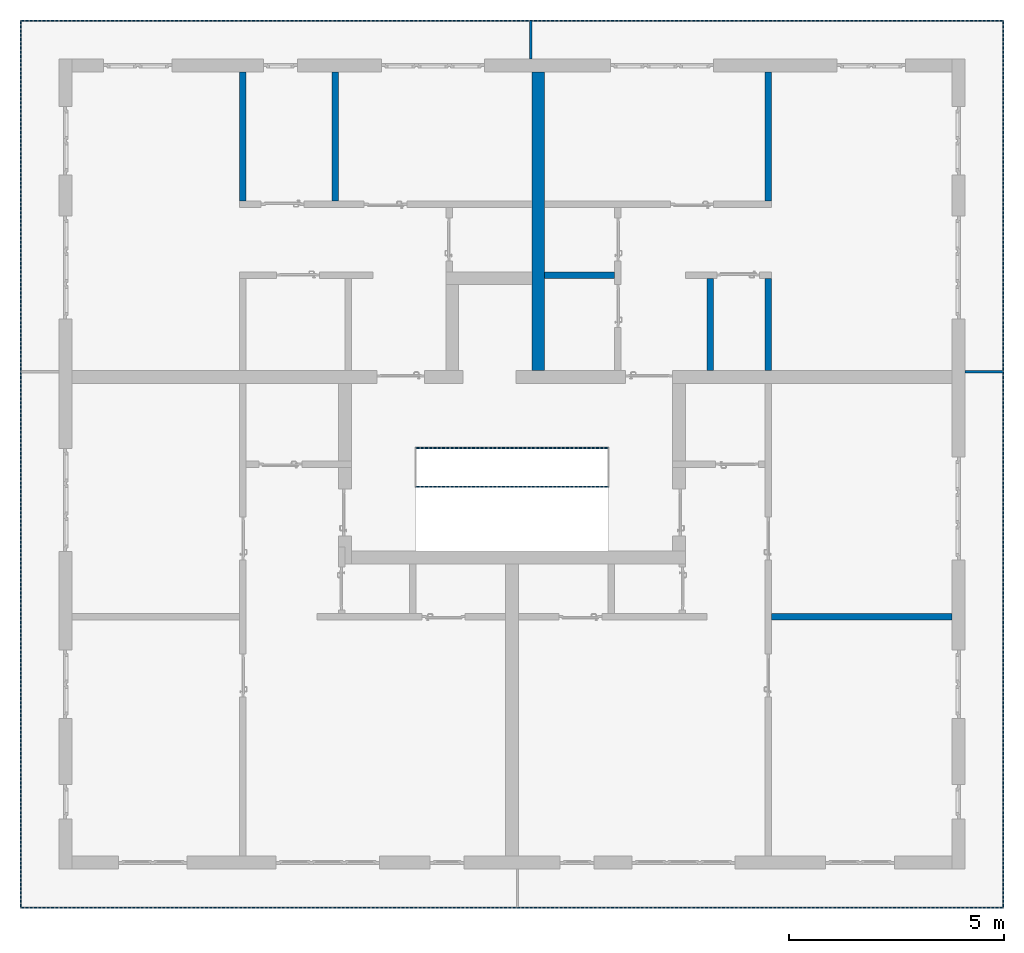
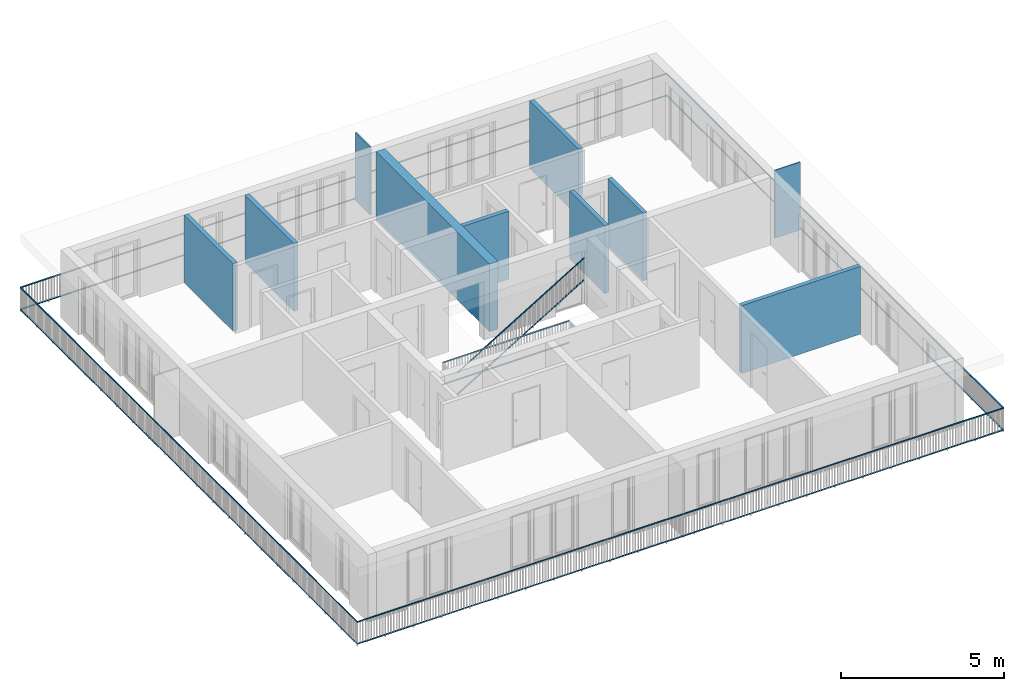
# One storey, part 30 of 54: 12 building element parts, 10 walls, 3 elements without a shape of their own.
"""IFC4 building model written with IfcOpenShell, lengths in metres."""

import ifcopenshell
import ifcopenshell.guid

model = None  # the IFC model being written
_history = None  # IfcOwnerHistory: only IFC2X3 demands one
_inside = {}  # id of a spatial element -> (the spatial element, [elements in it])
_under = {}  # id of a project, library or spatial element -> (it, [spatial elements below it])
_declared = {}  # id of a project -> (the project, [libraries it declares])
_typed = {}  # id of a type object -> (the type object, [elements of that type])
_made_of = {}  # id of a material, layer set ... -> (it, [elements and type objects made of it])


def new_model(schema):
    """Start an empty IFC model of exactly this schema.

    Asked for "IFC4X3", IfcOpenShell would pick the latest addendum, in which some entities
    have other attributes; the version numbers below select the first issue.
    IFC2X3 requires an IfcOwnerHistory on every rooted entity: one is made here for all.
    """
    global model, _history
    if schema == "IFC4X3":
        model = ifcopenshell.file(schema_version=(4, 3, 0, 0))
    else:
        model = ifcopenshell.file(schema=schema)
    _inside.clear()
    _under.clear()
    _declared.clear()
    _typed.clear()
    _made_of.clear()
    _history = None
    if model.schema == "IFC2X3":
        org = make("IfcOrganization", Name="unknown")
        user = make(
            "IfcPersonAndOrganization",
            ThePerson=make("IfcPerson", FamilyName="unknown"),
            TheOrganization=org,
        )
        app = make(
            "IfcApplication",
            ApplicationDeveloper=org,
            Version="unknown",
            ApplicationFullName="unknown",
            ApplicationIdentifier="unknown",
        )
        _history = make(
            "IfcOwnerHistory",
            OwningUser=user,
            OwningApplication=app,
            ChangeAction="ADDED",
            CreationDate=0,
        )
    return model


def make(cls, **values):
    """One entity of the class cls with the attributes given. An attribute that is None is left unset."""
    return model.create_entity(
        cls, **{name: value for name, value in values.items() if value is not None}
    )


def entity(cls, *values):
    """Any entity or typed value of the class cls, its attributes in the order of the schema. None: left unset."""
    e = model.create_entity(cls)
    for i, value in enumerate(values):
        if value is not None:
            e[i] = value
    return e


def rooted(cls, **values):
    """An entity with a GlobalId (a new one), such as an element, a storey or a relation."""
    return make(cls, GlobalId=ifcopenshell.guid.new(), OwnerHistory=_history, **values)


def si_unit(unit_type, name, prefix=None):
    """IfcSIUnit, for example si_unit("LENGTHUNIT", "METRE", prefix="MILLI")."""
    return make("IfcSIUnit", UnitType=unit_type, Prefix=prefix, Name=name)


def converted_unit(unit_type, name, factor, base, dimensions=None, offset=None):
    """IfcConversionBasedUnit, such as the inch: factor (a typed value) times the base unit."""
    return make(
        "IfcConversionBasedUnit"
        if offset is None
        else "IfcConversionBasedUnitWithOffset",
        ConversionOffset=offset,
        Dimensions=None
        if dimensions is None
        else entity("IfcDimensionalExponents", *dimensions),
        UnitType=unit_type,
        Name=name,
        ConversionFactor=make(
            "IfcMeasureWithUnit", ValueComponent=factor, UnitComponent=base
        ),
    )


def derived_unit(unit_type, elements):
    """IfcDerivedUnit: a product of units, each with its exponent."""
    return make(
        "IfcDerivedUnit",
        Elements=[
            make("IfcDerivedUnitElement", Unit=unit, Exponent=power)
            for unit, power in elements
        ],
        UnitType=unit_type,
    )


def assignment(units):
    """IfcUnitAssignment: the units of a project."""
    return None if units is None else make("IfcUnitAssignment", Units=units)


def point(xyz):
    """IfcCartesianPoint."""
    return None if xyz is None else make("IfcCartesianPoint", Coordinates=xyz)


def direction(xyz):
    """IfcDirection."""
    return None if xyz is None else make("IfcDirection", DirectionRatios=xyz)


def frame(location, z_axis=None, x_axis=None):
    """IfcAxis2Placement3D, a coordinate frame: its origin and axes. An axis left out is left unset."""
    return make(
        "IfcAxis2Placement3D",
        Location=point(location),
        Axis=direction(z_axis),
        RefDirection=direction(x_axis),
    )


def origin_with_axes():
    """The frame at (0, 0, 0) with the z axis (0, 0, 1) and the x axis (1, 0, 0) written out."""
    return frame((0.0, 0.0, 0.0), z_axis=(0.0, 0.0, 1.0), x_axis=(1.0, 0.0, 0.0))


def place(relative_to, where):
    """IfcLocalPlacement: puts the frame where relative to a parent placement (None: the world)."""
    return make(
        "IfcLocalPlacement", PlacementRelTo=relative_to, RelativePlacement=where
    )


def context(
    kind, dimensions, precision=None, world=None, true_north=None, identifier=None
):
    """IfcGeometricRepresentationContext, for example the 3D "Model" context."""
    return make(
        "IfcGeometricRepresentationContext",
        ContextIdentifier=identifier,
        ContextType=kind,
        CoordinateSpaceDimension=dimensions,
        Precision=precision,
        WorldCoordinateSystem=world,
        TrueNorth=true_north,
    )


def subcontext(parent, identifier, kind, view, scale=None):
    """IfcGeometricRepresentationSubContext, for example "Body" below "Model"."""
    return make(
        "IfcGeometricRepresentationSubContext",
        ContextIdentifier=identifier,
        ContextType=kind,
        ParentContext=parent,
        TargetScale=scale,
        TargetView=view,
    )


def project(units=None, contexts=None):
    """IfcProject with its units and contexts."""
    return rooted(
        "IfcProject",
        Name="project",
        RepresentationContexts=contexts,
        UnitsInContext=assignment(units),
    )


def spatial(cls, under=None, at=None, **own):
    """A site, building, storey or space (cls), placed at a placement, below another one or the project."""
    s = rooted(cls, ObjectPlacement=at, **own)
    if under is not None:
        _under.setdefault(under.id(), (under, []))[1].append(s)
    return s


def point_list(points):
    """IfcCartesianPointList2D or 3D."""
    cls = (
        "IfcCartesianPointList2D" if len(points[0]) == 2 else "IfcCartesianPointList3D"
    )
    return make(cls, CoordList=points)


def polygons(points, faces, closed=None, point_numbers=None):
    """IfcPolygonalFaceSet: a face is its outer loop, then its inner loops; points numbered from 1."""
    made = []
    for loops in faces:
        if len(loops) == 1:
            made.append(make("IfcIndexedPolygonalFace", CoordIndex=loops[0]))
        else:
            made.append(
                make(
                    "IfcIndexedPolygonalFaceWithVoids",
                    CoordIndex=loops[0],
                    InnerCoordIndices=loops[1:],
                )
            )
    return make(
        "IfcPolygonalFaceSet",
        Coordinates=point_list(points),
        Closed=closed,
        Faces=made,
        PnIndex=point_numbers,
    )


def shape(context_of_items, identifier, shape_type, items):
    """IfcShapeRepresentation: the items that make up one representation, for example the "Body"."""
    return make(
        "IfcShapeRepresentation",
        ContextOfItems=context_of_items,
        RepresentationIdentifier=identifier,
        RepresentationType=shape_type,
        Items=items,
    )


def material(Name=None, Category=None):
    """IfcMaterial."""
    return make("IfcMaterial", Name=Name, Category=Category)


def made_of(thing, what):
    """Note that an element or type object is made of a material, layer set ...; save() writes the relation."""
    if what is not None:
        _made_of.setdefault(what.id(), (what, []))[1].append(thing)
    return thing


def type_object(cls, material=None, **own):
    """A type object (cls), such as IfcWallType, which elements share."""
    return made_of(rooted(cls, **own), material)


def element(
    cls,
    number,
    at=None,
    inside=None,
    cuts=None,
    type_object=None,
    material=None,
    context=None,
    identifier="Body",
    shape_type=None,
    held_by="IfcProductDefinitionShape",
    body=None,
    shapes=None,
    **own,
):
    """One element of the class cls, such as IfcWall. Its Tag is "e" and its number.

    at: its placement. inside: the storey or other place that contains it. cuts: it is an
    opening in that element (IfcRelVoidsElement). A single representation is given by context,
    identifier, shape_type and body (its items); several are given by shapes. held_by: the class
    of the entity that holds the representations. save() writes the other relations.
    """
    e = rooted(cls, Tag="e%d" % number, ObjectPlacement=at, **own)
    if body is not None:
        shapes = [shape(context, identifier, shape_type, body)]
    if shapes is not None:
        e.Representation = make(held_by, Representations=shapes)
    if inside is not None:
        _inside.setdefault(inside.id(), (inside, []))[1].append(e)
    if cuts is not None:
        rooted(
            "IfcRelVoidsElement", RelatingBuildingElement=cuts, RelatedOpeningElement=e
        )
    if type_object is not None:
        _typed.setdefault(type_object.id(), (type_object, []))[1].append(e)
    return made_of(e, material)


def aggregate(whole, parts):
    """IfcRelAggregates: a whole, such as a stair, and the parts it consists of."""
    return rooted("IfcRelAggregates", RelatingObject=whole, RelatedObjects=parts)


def save(model, path):
    """Write the relations noted so far, then the file.

    IfcRelAggregates (storeys below a building ...), IfcRelContainedInSpatialStructure (elements
    in a storey), IfcRelDefinesByType, IfcRelAssociatesMaterial and IfcRelDeclares: one each for
    every whole, place, type object, material and project.
    """
    for whole, parts in _under.values():
        aggregate(whole, parts)
    for where, things in _inside.values():
        rooted(
            "IfcRelContainedInSpatialStructure",
            RelatedElements=things,
            RelatingStructure=where,
        )
    for kind, things in _typed.values():
        rooted("IfcRelDefinesByType", RelatedObjects=things, RelatingType=kind)
    for what, things in _made_of.values():
        rooted("IfcRelAssociatesMaterial", RelatedObjects=things, RelatingMaterial=what)
    for by, libraries in _declared.values():
        rooted("IfcRelDeclares", RelatingContext=by, RelatedDefinitions=libraries)
    model.write(path)


model = new_model("IFC4")

# Units and contexts
model_context = context("Model", 3, precision=1e-05, world=origin_with_axes(), true_north=direction((0.0, 1.0)))
body_context = subcontext(model_context, "Body", "Model", "MODEL_VIEW")
ifc_project = project(units=[si_unit("LENGTHUNIT", "METRE"), si_unit("AREAUNIT", "SQUARE_METRE"), si_unit("VOLUMEUNIT", "CUBIC_METRE"), converted_unit("PLANEANGLEUNIT", "DEGREE", entity("IfcPlaneAngleMeasure", 0.0174532925199), si_unit("PLANEANGLEUNIT", "RADIAN"), dimensions=[0, 0, 0, 0, 0, 0, 0]), converted_unit("TIMEUNIT", "Year", entity("IfcTimeMeasure", 31556926.0), si_unit("TIMEUNIT", "SECOND"), dimensions=[0, 0, 1, 0, 0, 0, 0]), si_unit("MASSUNIT", "GRAM", prefix="KILO"), si_unit("THERMODYNAMICTEMPERATUREUNIT", "DEGREE_CELSIUS"), si_unit("LUMINOUSINTENSITYUNIT", "LUMEN"), si_unit("ENERGYUNIT", "JOULE", prefix="MEGA"), derived_unit("THERMALCONDUCTANCEUNIT", [(si_unit("POWERUNIT", "WATT"), 1), (si_unit("LENGTHUNIT", "METRE"), -1), (si_unit("THERMODYNAMICTEMPERATUREUNIT", "KELVIN"), -1)]), derived_unit("SPECIFICHEATCAPACITYUNIT", [(si_unit("ENERGYUNIT", "JOULE"), 1), (si_unit("MASSUNIT", "GRAM", prefix="KILO"), -1), (si_unit("THERMODYNAMICTEMPERATUREUNIT", "KELVIN"), -1)]), derived_unit("MASSDENSITYUNIT", [(si_unit("MASSUNIT", "GRAM", prefix="KILO"), 1), (si_unit("VOLUMEUNIT", "CUBIC_METRE"), -1)])], contexts=[model_context])

# Site, building, storey
site_placement = place(None, origin_with_axes())
site = spatial("IfcSite", under=ifc_project, at=site_placement, CompositionType="ELEMENT")
building_placement = place(site_placement, origin_with_axes())
building = spatial("IfcBuilding", under=site, at=building_placement, CompositionType="ELEMENT")
storey_placement = place(building_placement, frame((0.0, 0.0, 6.29), z_axis=(0.0, 0.0, 1.0), x_axis=(1.0, 0.0, 0.0)))
storey = spatial("IfcBuildingStorey", under=building, at=storey_placement, Name="2. Geschoss", CompositionType="ELEMENT", Elevation=6.29)

# Walls
ifc_material_1 = material()
wall_type_1 = type_object("IfcWallType", Name="300", PredefinedType="NOTDEFINED")
wall_1_placement = place(storey_placement, frame((-0.742199380397, 1.37118776896, 0.0), z_axis=(0.0, 0.0, 1.0), x_axis=(0.0, 1.0, 0.0)))
element("IfcWall", 1, at=wall_1_placement, inside=storey, type_object=wall_type_1, material=ifc_material_1, Name="Wand-001", PredefinedType="NOTDEFINED", context=body_context, shape_type="Tessellation", body=[
    polygons([(7.25, 0.0, 0.0), (7.25, 0.0, 2.54), (7.25, -0.3, 2.54), (7.25, -0.3, 0.0), (0.3, 0.0, 0.0), (0.3, 0.0, 2.54), (0.3, -0.3, 2.54), (0.3, -0.3, 0.0)], [[[1, 2, 3, 4]], [[5, 6, 2, 1]], [[6, 7, 3, 2]], [[4, 3, 7, 8]], [[8, 5, 1, 4]], [[8, 7, 6, 5]]], closed=True),
])
wall_type_2 = type_object("IfcWallType", Name="150", PredefinedType="NOTDEFINED")
wall_2_placement = place(storey_placement, frame((-7.5421993804, 5.47118776896, 0.0), z_axis=(0.0, 0.0, 1.0), x_axis=(0.0, 1.0, 0.0)))
element("IfcWall", 2, at=wall_2_placement, inside=storey, type_object=wall_type_2, material=ifc_material_1, Name="Wand-002", PredefinedType="NOTDEFINED", context=body_context, shape_type="Tessellation", body=[
    polygons([(3.15, 0.0, 0.0), (3.15, 0.0, 2.54), (3.15, -0.15, 2.54), (3.15, -0.15, 0.0), (0.15, 0.0, 0.0), (0.15, 0.0, 2.54), (0.15, -0.15, 2.54), (0.15, -0.15, 0.0)], [[[1, 2, 3, 4]], [[5, 6, 2, 1]], [[6, 7, 3, 2]], [[4, 3, 7, 8]], [[5, 1, 4, 8]], [[8, 7, 6, 5]]], closed=True),
])
wall_3_placement = place(storey_placement, frame((3.3378006196, 1.37118776896, 0.0), z_axis=(0.0, 0.0, 1.0), x_axis=(0.0, 1.0, 0.0)))
element("IfcWall", 3, at=wall_3_placement, inside=storey, type_object=wall_type_2, material=ifc_material_1, Name="Wand-002", PredefinedType="NOTDEFINED", context=body_context, shape_type="Tessellation", body=[
    polygons([(2.45, 0.0, 0.0), (2.45, 0.0, 2.54), (2.45, -0.15, 2.54), (2.45, -0.15, 0.0), (0.3, 0.0, 0.0), (0.3, 0.0, 2.54), (0.3, -0.15, 2.54), (0.3, -0.15, 0.0)], [[[1, 2, 3, 4]], [[5, 6, 2, 1]], [[6, 7, 3, 2]], [[4, 3, 7, 8]], [[5, 1, 4, 8]], [[8, 7, 6, 5]]], closed=True),
])
wall_4_placement = place(storey_placement, frame((1.3378006196, 3.97118776896, 0.0), z_axis=(0.0, 0.0, 1.0), x_axis=(-1.0, 0.0, 0.0)))
element("IfcWall", 4, at=wall_4_placement, inside=storey, type_object=wall_type_2, material=ifc_material_1, Name="Wand-002", PredefinedType="NOTDEFINED", context=body_context, shape_type="Tessellation", body=[
    polygons([(1.78, 0.0, 0.0), (1.78, 0.0, 2.54), (0.15, 0.0, 2.54), (0.15, 0.0, 0.0), (1.78, 0.15, 0.0), (1.78, 0.15, 2.54), (0.15, 0.15, 2.54), (0.15, 0.15, 0.0)], [[[1, 2, 3, 4]], [[5, 6, 2, 1]], [[6, 7, 3, 2]], [[4, 3, 7, 8]], [[8, 5, 1, 4]], [[8, 7, 6, 5]]], closed=True),
])
for number, where, z_axis, x_axis, name in (
    (5, (-5.3921993804, 5.47118776896, 0.0), (0.0, 0.0, 1.0), (0.0, 1.0, 0.0), "Wand-002"),
    (6, (4.6878006196, 5.47118776896, 0.0), (0.0, 0.0, 1.0), (0.0, 1.0, 0.0), "Wand-002"),
):
    element("IfcWall", number, at=place(storey_placement, frame(where, z_axis=z_axis, x_axis=x_axis)), inside=storey, type_object=wall_type_2, material=ifc_material_1, Name=name, PredefinedType="NOTDEFINED", context=body_context, shape_type="Tessellation", body=[
        polygons([(3.15, 0.0, 0.0), (3.15, 0.0, 2.54), (3.15, -0.15, 2.54), (3.15, -0.15, 0.0), (0.15, 0.0, 0.0), (0.15, 0.0, 2.54), (0.15, -0.15, 2.54), (0.15, -0.15, 0.0)], [[[1, 2, 3, 4]], [[5, 6, 2, 1]], [[6, 7, 3, 2]], [[4, 3, 7, 8]], [[5, 1, 4, 8]], [[8, 7, 6, 5]]], closed=True),
    ])
wall_5_placement = place(storey_placement, frame((9.3378006196, -4.12881223104, 0.0), z_axis=(0.0, 0.0, 1.0), x_axis=(-1.0, 0.0, 0.0)))
element("IfcWall", 7, at=wall_5_placement, inside=storey, type_object=wall_type_2, material=ifc_material_1, Name="Wand-004", PredefinedType="NOTDEFINED", context=body_context, shape_type="Tessellation", body=[
    polygons([(4.5, -0.15, 0.0), (4.5, -0.15, 2.54), (0.3, -0.15, 2.54), (0.3, -0.15, 0.0), (4.5, 0.0, 0.0), (4.5, 0.0, 2.54), (0.3, 0.0, 2.54), (0.3, 0.0, 0.0)], [[[1, 2, 3, 4]], [[5, 6, 2, 1]], [[6, 7, 3, 2]], [[4, 3, 7, 8]], [[8, 5, 1, 4]], [[8, 7, 6, 5]]], closed=True),
])
wall_6_placement = place(storey_placement, frame((4.6878006196, 1.37118776896, 0.0), z_axis=(0.0, 0.0, 1.0), x_axis=(0.0, 1.0, 0.0)))
element("IfcWall", 8, at=wall_6_placement, inside=storey, type_object=wall_type_2, material=ifc_material_1, Name="Wand-002", PredefinedType="NOTDEFINED", context=body_context, shape_type="Tessellation", body=[
    polygons([(2.45, 0.0, 0.0), (2.45, 0.0, 2.54), (2.45, -0.15, 2.54), (2.45, -0.15, 0.0), (0.3, 0.0, 0.0), (0.3, 0.0, 2.54), (0.3, -0.15, 2.54), (0.3, -0.15, 0.0)], [[[1, 2, 3, 4]], [[5, 6, 2, 1]], [[6, 7, 3, 2]], [[4, 3, 7, 8]], [[5, 1, 4, 8]], [[8, 7, 6, 5]]], closed=True),
])
ifc_material_2 = material()
wall_type_3 = type_object("IfcWallType", Name="50", PredefinedType="NOTDEFINED")
wall_7_placement = place(storey_placement, frame((-0.742199380397, 9.82118776896, 0.0), z_axis=(0.0, 0.0, 1.0), x_axis=(0.0, -1.0, 0.0)))
element("IfcWall", 9, at=wall_7_placement, inside=storey, type_object=wall_type_3, material=ifc_material_2, Name="Wand-003", PredefinedType="NOTDEFINED", context=body_context, shape_type="Tessellation", body=[
    polygons([(0.0, -0.05, 2.54), (0.0, 0.0, 2.54), (0.0, 0.0, 0.0), (0.0, -0.05, 0.0), (0.9, 0.0, 2.54), (0.9, -0.05, 2.54), (0.9, 0.0, 0.0), (0.9, -0.05, 0.0)], [[[1, 2, 3, 4]], [[5, 2, 1, 6]], [[2, 5, 7, 3]], [[7, 8, 4, 3]], [[6, 1, 4, 8]], [[5, 6, 8, 7]]], closed=True),
])
wall_8_placement = place(storey_placement, frame((9.0378006196, 1.67118776896, 0.0), z_axis=(0.0, 0.0, 1.0), x_axis=(1.0, 0.0, 0.0)))
element("IfcWall", 10, at=wall_8_placement, inside=storey, type_object=wall_type_3, material=ifc_material_2, Name="Wand-003", PredefinedType="NOTDEFINED", context=body_context, shape_type="Tessellation", body=[
    polygons([(0.3, 0.0, 2.54), (1.2, 0.0, 2.54), (1.2, 0.0, 0.0), (0.3, 0.0, 0.0), (1.2, -0.05, 2.54), (0.3, -0.05, 2.54), (1.2, -0.05, 0.0), (0.3, -0.05, 0.0)], [[[1, 2, 3, 4]], [[5, 2, 1, 6]], [[2, 5, 7, 3]], [[4, 3, 7, 8]], [[6, 1, 4, 8]], [[5, 6, 8, 7]]], closed=True),
])

# Space
space_1_placement = place(storey_placement, frame((-3.4421993804, -2.52881223104, 0.0), z_axis=(0.0, 0.0, 1.0), x_axis=(1.0, 0.0, 0.0)))
space_1 = spatial("IfcSpace", under=storey, at=space_1_placement, CompositionType="ELEMENT", PredefinedType="INTERNAL")

# Railing, building element parts
railing_type = type_object("IfcRailingType", PredefinedType="NOTDEFINED")
railing_1_placement = place(space_1_placement, frame((0.0, 1.5, 0.0), z_axis=(0.0, 0.0, 1.0), x_axis=(1.0, 0.0, 0.0)))
railing_1 = element("IfcRailing", 11, at=railing_1_placement, inside=space_1, type_object=railing_type, PredefinedType="NOTDEFINED")
ifc_material_3 = material()
building_element_part_1_placement = place(railing_1_placement, origin_with_axes())
building_element_part_1 = element("IfcBuildingElementPart", 12, at=building_element_part_1_placement, material=ifc_material_3, PredefinedType="NOTDEFINED", context=body_context, shape_type="Tessellation", body=[
    polygons([(0.0125, 0.8875, 0.9), (0.0125, 0.8875, 0.875), (4.4675, 0.8875, 0.875), (4.4675, 0.8875, 0.9), (-0.0125, 0.9125, 0.9), (-0.0125, 0.9125, 0.875), (4.4925, 0.9125, 0.875), (4.4925, 0.9125, 0.9)], [[[1, 2, 3, 4]], [[1, 5, 6, 2]], [[2, 6, 7, 3]], [[4, 3, 7, 8]], [[5, 1, 4, 8]], [[6, 5, 8, 7]]], closed=True),
])
building_element_part_2_placement = place(railing_1_placement, origin_with_axes())
building_element_part_2 = element("IfcBuildingElementPart", 13, at=building_element_part_2_placement, material=ifc_material_3, PredefinedType="NOTDEFINED", context=body_context, shape_type="Tessellation", body=[
    polygons([(0.0125, 0.8875, 0.0825), (0.0125, 0.8875, 0.0575), (4.4675, 0.8875, 0.0575), (4.4675, 0.8875, 0.0825), (-0.0125, 0.9125, 0.0825), (-0.0125, 0.9125, 0.0575), (4.4925, 0.9125, 0.0575), (4.4925, 0.9125, 0.0825)], [[[1, 2, 3, 4]], [[1, 5, 6, 2]], [[2, 6, 7, 3]], [[4, 3, 7, 8]], [[5, 1, 4, 8]], [[6, 5, 8, 7]]], closed=True),
])
aggregate(railing_1, [building_element_part_1, building_element_part_2])

railing_2_placement = place(space_1_placement, frame((0.0, 1.5, 0.17), z_axis=(0.0, 0.0, 1.0), x_axis=(1.0, 0.0, 0.0)))
railing_2 = element("IfcRailing", 14, at=railing_2_placement, inside=space_1, type_object=railing_type, PredefinedType="NOTDEFINED")
building_element_part_3_placement = place(railing_2_placement, origin_with_axes())
building_element_part_3 = element("IfcBuildingElementPart", 15, at=building_element_part_3_placement, material=ifc_material_3, PredefinedType="NOTDEFINED", context=body_context, shape_type="Tessellation", body=[
    polygons([(0.0, -0.0125, 0.9), (0.012974453356, -0.0125, 0.878630312119), (4.49297445336, -0.0125, 3.59863031212), (4.48, -0.0125, 3.62), (0.0, 0.0125, 0.9), (0.012974453356, 0.0125, 0.878630312119), (4.49297445336, 0.0125, 3.59863031212), (4.48, 0.0125, 3.62)], [[[1, 2, 3, 4]], [[1, 5, 6, 2]], [[2, 6, 7, 3]], [[4, 3, 7, 8]], [[5, 1, 4, 8]], [[6, 5, 8, 7]]], closed=True),
])
building_element_part_4_placement = place(railing_2_placement, origin_with_axes())
building_element_part_4 = element("IfcBuildingElementPart", 16, at=building_element_part_4_placement, material=ifc_material_3, PredefinedType="NOTDEFINED", context=body_context, shape_type="Tessellation", body=[
    polygons([(-0.00648722667802, -0.0125, 0.0806848439403), (0.00648722667802, -0.0125, 0.0593151560597), (4.48648722668, -0.0125, 2.77931515606), (4.47351277332, -0.0125, 2.80068484394), (-0.00648722667802, 0.0125, 0.0806848439403), (0.00648722667802, 0.0125, 0.0593151560597), (4.48648722668, 0.0125, 2.77931515606), (4.47351277332, 0.0125, 2.80068484394)], [[[1, 2, 3, 4]], [[1, 5, 6, 2]], [[2, 6, 7, 3]], [[4, 3, 7, 8]], [[5, 1, 4, 8]], [[6, 5, 8, 7]]], closed=True),
])
aggregate(railing_2, [building_element_part_3, building_element_part_4])

# Space
space_2_placement = place(storey_placement, frame((10.2378006196, 9.82118769833, 0.0), z_axis=(0.0, 0.0, 1.0), x_axis=(-1.0, 0.0, 0.0)))
space_2 = spatial("IfcSpace", under=storey, at=space_2_placement, CompositionType="ELEMENT", PredefinedType="EXTERNAL")

# Railing, building element parts
railing_3_placement = place(space_2_placement, frame((0.0, -7.06315681498e-08, 0.0), z_axis=(0.0, 0.0, 1.0), x_axis=(-1.0, 0.0, 0.0)))
railing_3 = element("IfcRailing", 17, at=railing_3_placement, inside=space_2, type_object=railing_type, PredefinedType="NOTDEFINED")
building_element_part_5_placement = place(railing_3_placement, origin_with_axes())
building_element_part_5 = element("IfcBuildingElementPart", 18, at=building_element_part_5_placement, material=ifc_material_3, PredefinedType="NOTDEFINED", context=body_context, shape_type="Tessellation", body=[
    polygons([(0.0, 0.0125, 0.9), (0.0, 0.0125, 0.875), (-22.8925, 0.0125, 0.875), (-22.8925, 0.0125, 0.9), (0.0, -0.0125, 0.9), (0.0, -0.0125, 0.875), (-22.8675, -0.0125, 0.875), (-22.8675, -0.0125, 0.9)], [[[1, 2, 3, 4]], [[1, 5, 6, 2]], [[2, 6, 7, 3]], [[4, 3, 7, 8]], [[5, 1, 4, 8]], [[6, 5, 8, 7]]], closed=True),
])
building_element_part_6_placement = place(railing_3_placement, origin_with_axes())
building_element_part_6 = element("IfcBuildingElementPart", 19, at=building_element_part_6_placement, material=ifc_material_3, PredefinedType="NOTDEFINED", context=body_context, shape_type="Tessellation", body=[
    polygons([(0.0, 0.0125, 0.0825), (0.0, 0.0125, 0.0575), (-22.8925, 0.0125, 0.0575), (-22.8925, 0.0125, 0.0825), (0.0, -0.0125, 0.0825), (0.0, -0.0125, 0.0575), (-22.8675, -0.0125, 0.0575), (-22.8675, -0.0125, 0.0825)], [[[1, 2, 3, 4]], [[1, 5, 6, 2]], [[2, 6, 7, 3]], [[4, 3, 7, 8]], [[5, 1, 4, 8]], [[6, 5, 8, 7]]], closed=True),
])
building_element_part_7_placement = place(railing_3_placement, origin_with_axes())
building_element_part_7 = element("IfcBuildingElementPart", 20, at=building_element_part_7_placement, material=ifc_material_3, PredefinedType="NOTDEFINED", context=body_context, shape_type="Tessellation", body=[
    polygons([(-22.8925, 0.0125, 0.9), (-22.8925, 0.0125, 0.875), (-22.8925, -20.6625, 0.875), (-22.8925, -20.6625, 0.9), (-22.8675, -0.0125, 0.9), (-22.8675, -0.0125, 0.875), (-22.8675, -20.6375, 0.875), (-22.8675, -20.6375, 0.9)], [[[1, 2, 3, 4]], [[1, 5, 6, 2]], [[2, 6, 7, 3]], [[4, 3, 7, 8]], [[5, 1, 4, 8]], [[6, 5, 8, 7]]], closed=True),
])
building_element_part_8_placement = place(railing_3_placement, origin_with_axes())
building_element_part_8 = element("IfcBuildingElementPart", 21, at=building_element_part_8_placement, material=ifc_material_3, PredefinedType="NOTDEFINED", context=body_context, shape_type="Tessellation", body=[
    polygons([(-22.8925, 0.0125, 0.0825), (-22.8925, 0.0125, 0.0575), (-22.8925, -20.6625, 0.0575), (-22.8925, -20.6625, 0.0825), (-22.8675, -0.0125, 0.0825), (-22.8675, -0.0125, 0.0575), (-22.8675, -20.6375, 0.0575), (-22.8675, -20.6375, 0.0825)], [[[1, 2, 3, 4]], [[1, 5, 6, 2]], [[2, 6, 7, 3]], [[4, 3, 7, 8]], [[5, 1, 4, 8]], [[6, 5, 8, 7]]], closed=True),
])
building_element_part_9_placement = place(railing_3_placement, origin_with_axes())
building_element_part_9 = element("IfcBuildingElementPart", 22, at=building_element_part_9_placement, material=ifc_material_3, PredefinedType="NOTDEFINED", context=body_context, shape_type="Tessellation", body=[
    polygons([(-22.8925, -20.6625, 0.9), (-22.8925, -20.6625, 0.875), (0.0125, -20.6625, 0.875), (0.0125, -20.6625, 0.9), (-22.8675, -20.6375, 0.9), (-22.8675, -20.6375, 0.875), (-0.0125, -20.6375, 0.875), (-0.0125, -20.6375, 0.9)], [[[1, 2, 3, 4]], [[1, 5, 6, 2]], [[2, 6, 7, 3]], [[4, 3, 7, 8]], [[5, 1, 4, 8]], [[6, 5, 8, 7]]], closed=True),
])
building_element_part_10_placement = place(railing_3_placement, origin_with_axes())
building_element_part_10 = element("IfcBuildingElementPart", 23, at=building_element_part_10_placement, material=ifc_material_3, PredefinedType="NOTDEFINED", context=body_context, shape_type="Tessellation", body=[
    polygons([(-22.8925, -20.6625, 0.0825), (-22.8925, -20.6625, 0.0575), (0.0125, -20.6625, 0.0575), (0.0125, -20.6625, 0.0825), (-22.8675, -20.6375, 0.0825), (-22.8675, -20.6375, 0.0575), (-0.0125, -20.6375, 0.0575), (-0.0125, -20.6375, 0.0825)], [[[1, 2, 3, 4]], [[1, 5, 6, 2]], [[2, 6, 7, 3]], [[4, 3, 7, 8]], [[5, 1, 4, 8]], [[6, 5, 8, 7]]], closed=True),
])
building_element_part_11_placement = place(railing_3_placement, origin_with_axes())
building_element_part_11 = element("IfcBuildingElementPart", 24, at=building_element_part_11_placement, material=ifc_material_3, PredefinedType="NOTDEFINED", context=body_context, shape_type="Tessellation", body=[
    polygons([(0.0125, -20.6625, 0.9), (0.0125, -20.6625, 0.875), (0.0125, 0.0, 0.875), (0.0125, 0.0, 0.9), (-0.0125, -20.6375, 0.9), (-0.0125, -20.6375, 0.875), (-0.0125, 0.0, 0.875), (-0.0125, 0.0, 0.9)], [[[1, 2, 3, 4]], [[1, 5, 6, 2]], [[2, 6, 7, 3]], [[4, 3, 7, 8]], [[5, 1, 4, 8]], [[6, 5, 8, 7]]], closed=True),
])
building_element_part_12_placement = place(railing_3_placement, origin_with_axes())
building_element_part_12 = element("IfcBuildingElementPart", 25, at=building_element_part_12_placement, material=ifc_material_3, PredefinedType="NOTDEFINED", context=body_context, shape_type="Tessellation", body=[
    polygons([(0.0125, -20.6625, 0.0825), (0.0125, -20.6625, 0.0575), (0.0125, 0.0, 0.0575), (0.0125, 0.0, 0.0825), (-0.0125, -20.6375, 0.0825), (-0.0125, -20.6375, 0.0575), (-0.0125, 0.0, 0.0575), (-0.0125, 0.0, 0.0825)], [[[1, 2, 3, 4]], [[1, 5, 6, 2]], [[2, 6, 7, 3]], [[4, 3, 7, 8]], [[5, 1, 4, 8]], [[6, 5, 8, 7]]], closed=True),
])
aggregate(railing_3, [building_element_part_5, building_element_part_6, building_element_part_7, building_element_part_8, building_element_part_9, building_element_part_10, building_element_part_11, building_element_part_12])

save(model, "model.ifc")
